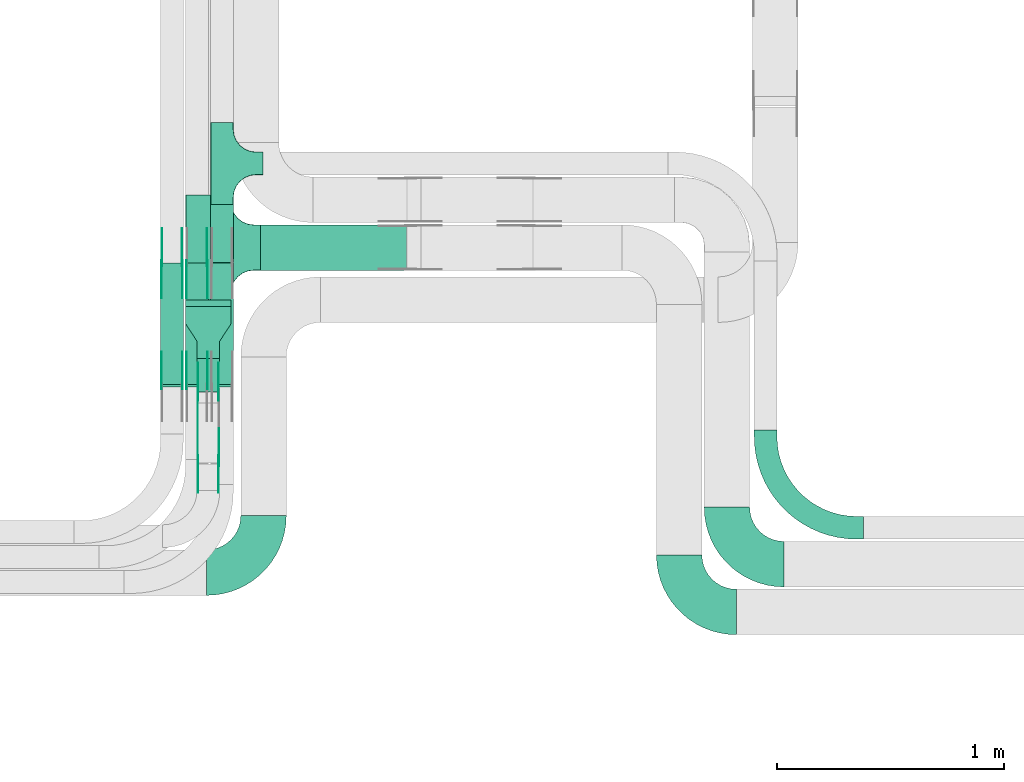
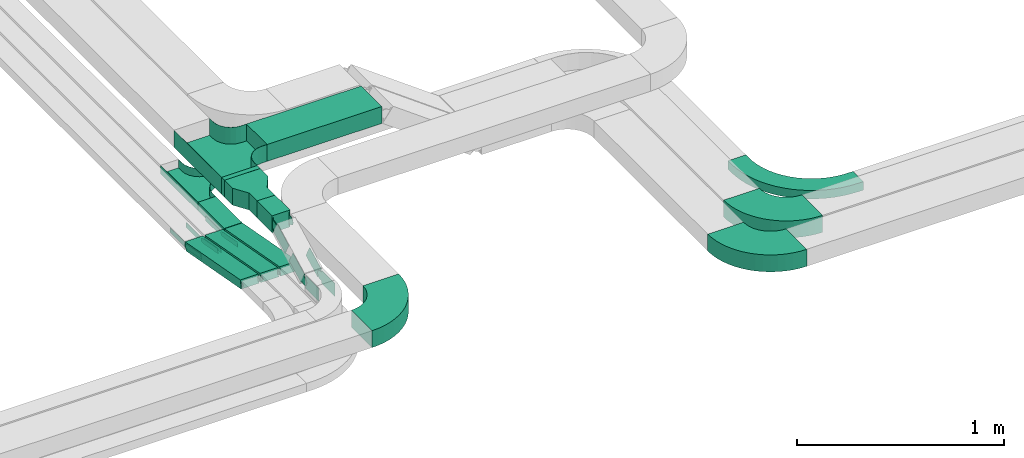
# One storey, part 10 of 23: 25 flow fittings, 7 flow segments.
"""IFC2X3 building model written with IfcOpenShell, lengths in millimetres."""

import ifcopenshell
import ifcopenshell.guid

model = None  # the IFC model being written
_history = None  # IfcOwnerHistory: only IFC2X3 demands one
_inside = {}  # id of a spatial element -> (the spatial element, [elements in it])
_under = {}  # id of a project, library or spatial element -> (it, [spatial elements below it])
_declared = {}  # id of a project -> (the project, [libraries it declares])
_typed = {}  # id of a type object -> (the type object, [elements of that type])
_made_of = {}  # id of a material, layer set ... -> (it, [elements and type objects made of it])


def new_model(schema):
    """Start an empty IFC model of exactly this schema.

    Asked for "IFC4X3", IfcOpenShell would pick the latest addendum, in which some entities
    have other attributes; the version numbers below select the first issue.
    IFC2X3 requires an IfcOwnerHistory on every rooted entity: one is made here for all.
    """
    global model, _history
    if schema == "IFC4X3":
        model = ifcopenshell.file(schema_version=(4, 3, 0, 0))
    else:
        model = ifcopenshell.file(schema=schema)
    _inside.clear()
    _under.clear()
    _declared.clear()
    _typed.clear()
    _made_of.clear()
    _history = None
    if model.schema == "IFC2X3":
        org = make("IfcOrganization", Name="unknown")
        user = make(
            "IfcPersonAndOrganization",
            ThePerson=make("IfcPerson", FamilyName="unknown"),
            TheOrganization=org,
        )
        app = make(
            "IfcApplication",
            ApplicationDeveloper=org,
            Version="unknown",
            ApplicationFullName="unknown",
            ApplicationIdentifier="unknown",
        )
        _history = make(
            "IfcOwnerHistory",
            OwningUser=user,
            OwningApplication=app,
            ChangeAction="ADDED",
            CreationDate=0,
        )
    return model


def make(cls, **values):
    """One entity of the class cls with the attributes given. An attribute that is None is left unset."""
    return model.create_entity(
        cls, **{name: value for name, value in values.items() if value is not None}
    )


def entity(cls, *values):
    """Any entity or typed value of the class cls, its attributes in the order of the schema. None: left unset."""
    e = model.create_entity(cls)
    for i, value in enumerate(values):
        if value is not None:
            e[i] = value
    return e


def rooted(cls, **values):
    """An entity with a GlobalId (a new one), such as an element, a storey or a relation."""
    return make(cls, GlobalId=ifcopenshell.guid.new(), OwnerHistory=_history, **values)


def si_unit(unit_type, name, prefix=None):
    """IfcSIUnit, for example si_unit("LENGTHUNIT", "METRE", prefix="MILLI")."""
    return make("IfcSIUnit", UnitType=unit_type, Prefix=prefix, Name=name)


def converted_unit(unit_type, name, factor, base, dimensions=None, offset=None):
    """IfcConversionBasedUnit, such as the inch: factor (a typed value) times the base unit."""
    return make(
        "IfcConversionBasedUnit"
        if offset is None
        else "IfcConversionBasedUnitWithOffset",
        ConversionOffset=offset,
        Dimensions=None
        if dimensions is None
        else entity("IfcDimensionalExponents", *dimensions),
        UnitType=unit_type,
        Name=name,
        ConversionFactor=make(
            "IfcMeasureWithUnit", ValueComponent=factor, UnitComponent=base
        ),
    )


def derived_unit(unit_type, elements):
    """IfcDerivedUnit: a product of units, each with its exponent."""
    return make(
        "IfcDerivedUnit",
        Elements=[
            make("IfcDerivedUnitElement", Unit=unit, Exponent=power)
            for unit, power in elements
        ],
        UnitType=unit_type,
    )


def assignment(units):
    """IfcUnitAssignment: the units of a project."""
    return None if units is None else make("IfcUnitAssignment", Units=units)


def point(xyz):
    """IfcCartesianPoint."""
    return None if xyz is None else make("IfcCartesianPoint", Coordinates=xyz)


def direction(xyz):
    """IfcDirection."""
    return None if xyz is None else make("IfcDirection", DirectionRatios=xyz)


def frame(location, z_axis=None, x_axis=None):
    """IfcAxis2Placement3D, a coordinate frame: its origin and axes. An axis left out is left unset."""
    return make(
        "IfcAxis2Placement3D",
        Location=point(location),
        Axis=direction(z_axis),
        RefDirection=direction(x_axis),
    )


def frame_2d(location, x_axis=None):
    """IfcAxis2Placement2D, a coordinate frame in the plane: its origin and x axis."""
    return make(
        "IfcAxis2Placement2D", Location=point(location), RefDirection=direction(x_axis)
    )


def origin():
    """The frame at (0, 0, 0) with its axes left unset."""
    return frame((0.0, 0.0, 0.0))


def origin_2d_with_axis():
    """The frame at (0, 0) in the plane with the x axis (1, 0) written out."""
    return frame_2d((0.0, 0.0), x_axis=(1.0, 0.0))


def place(relative_to, where):
    """IfcLocalPlacement: puts the frame where relative to a parent placement (None: the world)."""
    return make(
        "IfcLocalPlacement", PlacementRelTo=relative_to, RelativePlacement=where
    )


def context(
    kind, dimensions, precision=None, world=None, true_north=None, identifier=None
):
    """IfcGeometricRepresentationContext, for example the 3D "Model" context."""
    return make(
        "IfcGeometricRepresentationContext",
        ContextIdentifier=identifier,
        ContextType=kind,
        CoordinateSpaceDimension=dimensions,
        Precision=precision,
        WorldCoordinateSystem=world,
        TrueNorth=true_north,
    )


def subcontext(parent, identifier, kind, view, scale=None):
    """IfcGeometricRepresentationSubContext, for example "Body" below "Model"."""
    return make(
        "IfcGeometricRepresentationSubContext",
        ContextIdentifier=identifier,
        ContextType=kind,
        ParentContext=parent,
        TargetScale=scale,
        TargetView=view,
    )


def project(units=None, contexts=None):
    """IfcProject with its units and contexts."""
    return rooted(
        "IfcProject",
        Name="project",
        RepresentationContexts=contexts,
        UnitsInContext=assignment(units),
    )


def spatial(cls, under=None, at=None, **own):
    """A site, building, storey or space (cls), placed at a placement, below another one or the project."""
    s = rooted(cls, ObjectPlacement=at, **own)
    if under is not None:
        _under.setdefault(under.id(), (under, []))[1].append(s)
    return s


def polyline(points):
    """IfcPolyline through the points."""
    return make("IfcPolyline", Points=[point(p) for p in points])


def circle_curve(where, radius):
    """IfcCircle in the frame where."""
    return make("IfcCircle", Position=where, Radius=radius)


def parameter(value):
    """IfcParameterValue: where a trimmed curve begins or ends, as a parameter of its basis curve."""
    return model.create_entity("IfcParameterValue", value)


def trimmed(basis, trim1, trim2, sense, master):
    """IfcTrimmedCurve: the piece of a basis curve between two trims."""
    return make(
        "IfcTrimmedCurve",
        BasisCurve=basis,
        Trim1=trim1,
        Trim2=trim2,
        SenseAgreement=sense,
        MasterRepresentation=master,
    )


def segment(curve, same_sense, transition):
    """IfcCompositeCurveSegment."""
    return make(
        "IfcCompositeCurveSegment",
        Transition=transition,
        SameSense=same_sense,
        ParentCurve=curve,
    )


def composite_curve(segments, self_intersect=None):
    """IfcCompositeCurve: segments joined end to end."""
    return make("IfcCompositeCurve", Segments=segments, SelfIntersect=self_intersect)


def profile(cls, at=None, kind="AREA", **sizes):
    """A parametric profile (cls). Its sizes go by their IFC names, for example OverallWidth=200.0."""
    return make(cls, ProfileType=kind, Position=at, **sizes)


def rectangle(**sizes):
    """IfcRectangleProfileDef."""
    return profile("IfcRectangleProfileDef", **sizes)


def outline(outer, holes=None, kind="AREA"):
    """IfcArbitraryClosedProfileDef: a profile drawn as a closed curve; with holes, ...WithVoids."""
    if holes is None:
        return make("IfcArbitraryClosedProfileDef", ProfileType=kind, OuterCurve=outer)
    return make(
        "IfcArbitraryProfileDefWithVoids",
        ProfileType=kind,
        OuterCurve=outer,
        InnerCurves=holes,
    )


def extrude(swept, where, along, depth):
    """IfcExtrudedAreaSolid: the profile swept, set in the frame where, extruded along a direction by depth."""
    return make(
        "IfcExtrudedAreaSolid",
        SweptArea=swept,
        Position=where,
        ExtrudedDirection=direction(along),
        Depth=depth,
    )


def faces_of(points, faces, orient=None, outer=None):
    """IfcFace entities. A face is a list of loops; a loop is a list of indices into points, from 0.

    orient and outer hold one flag for each loop. By default every Orientation is true, the
    first loop of a face is its IfcFaceOuterBound and the others are IfcFaceBound.
    """
    made = []
    for i, loops in enumerate(faces):
        bounds = []
        for j, loop in enumerate(loops):
            is_outer = j == 0 if outer is None else outer[i][j]
            bounds.append(
                make(
                    "IfcFaceOuterBound" if is_outer else "IfcFaceBound",
                    Bound=make("IfcPolyLoop", Polygon=[points[k] for k in loop]),
                    Orientation=True if orient is None else orient[i][j],
                )
            )
        made.append(make("IfcFace", Bounds=bounds))
    return made


def faceted_brep(points, faces, orient=None, outer=None, voids=None):
    """IfcFacetedBrep: a solid bounded by flat faces; with voids (closed shells), ...WithVoids."""
    shared = [point(p) for p in points]
    hull = make("IfcClosedShell", CfsFaces=faces_of(shared, faces, orient, outer))
    if voids is None:
        return make("IfcFacetedBrep", Outer=hull)
    return make(
        "IfcFacetedBrepWithVoids",
        Outer=hull,
        Voids=[
            make(cls, CfsFaces=faces_of(shared, fs, o, b)) for cls, fs, o, b in voids
        ],
    )


def shape(context_of_items, identifier, shape_type, items):
    """IfcShapeRepresentation: the items that make up one representation, for example the "Body"."""
    return make(
        "IfcShapeRepresentation",
        ContextOfItems=context_of_items,
        RepresentationIdentifier=identifier,
        RepresentationType=shape_type,
        Items=items,
    )


def source(mapping_origin, context_of_items, identifier, shape_type, items):
    """IfcRepresentationMap: a shape defined once, which mapped items show again and again."""
    return make(
        "IfcRepresentationMap",
        MappingOrigin=mapping_origin,
        MappedRepresentation=shape(context_of_items, identifier, shape_type, items),
    )


def transform(
    local_origin,
    x_axis=None,
    y_axis=None,
    z_axis=None,
    scale=None,
    scale2=None,
    scale3=None,
    uniform=True,
):
    """IfcCartesianTransformationOperator3D, or its non-uniform kind. x_axis, y_axis, z_axis: its Axis1, 2, 3."""
    if uniform:
        return make(
            "IfcCartesianTransformationOperator3D",
            Axis1=direction(x_axis),
            Axis2=direction(y_axis),
            LocalOrigin=point(local_origin),
            Scale=scale,
            Axis3=direction(z_axis),
        )
    return make(
        "IfcCartesianTransformationOperator3DnonUniform",
        Axis1=direction(x_axis),
        Axis2=direction(y_axis),
        LocalOrigin=point(local_origin),
        Scale=scale,
        Axis3=direction(z_axis),
        Scale2=scale2,
        Scale3=scale3,
    )


def mapped(mapping_source, mapping_target):
    """IfcMappedItem: shows the shape of a source again, moved by a transform."""
    return make(
        "IfcMappedItem", MappingSource=mapping_source, MappingTarget=mapping_target
    )


def material(Name=None, Category=None):
    """IfcMaterial."""
    return make("IfcMaterial", Name=Name, Category=Category)


def made_of(thing, what):
    """Note that an element or type object is made of a material, layer set ...; save() writes the relation."""
    if what is not None:
        _made_of.setdefault(what.id(), (what, []))[1].append(thing)
    return thing


def type_object(cls, material=None, **own):
    """A type object (cls), such as IfcWallType, which elements share."""
    return made_of(rooted(cls, **own), material)


def type_shapes(of_type, sources):
    """Give a type object the sources (RepresentationMaps) that its elements show as mapped items."""
    of_type.RepresentationMaps = sources


def element(
    cls,
    number,
    at=None,
    inside=None,
    cuts=None,
    type_object=None,
    material=None,
    context=None,
    identifier="Body",
    shape_type=None,
    held_by="IfcProductDefinitionShape",
    body=None,
    shapes=None,
    **own,
):
    """One element of the class cls, such as IfcWall. Its Tag is "e" and its number.

    at: its placement. inside: the storey or other place that contains it. cuts: it is an
    opening in that element (IfcRelVoidsElement). A single representation is given by context,
    identifier, shape_type and body (its items); several are given by shapes. held_by: the class
    of the entity that holds the representations. save() writes the other relations.
    """
    e = rooted(cls, Tag="e%d" % number, ObjectPlacement=at, **own)
    if body is not None:
        shapes = [shape(context, identifier, shape_type, body)]
    if shapes is not None:
        e.Representation = make(held_by, Representations=shapes)
    if inside is not None:
        _inside.setdefault(inside.id(), (inside, []))[1].append(e)
    if cuts is not None:
        rooted(
            "IfcRelVoidsElement", RelatingBuildingElement=cuts, RelatedOpeningElement=e
        )
    if type_object is not None:
        _typed.setdefault(type_object.id(), (type_object, []))[1].append(e)
    return made_of(e, material)


def aggregate(whole, parts):
    """IfcRelAggregates: a whole, such as a stair, and the parts it consists of."""
    return rooted("IfcRelAggregates", RelatingObject=whole, RelatedObjects=parts)


def save(model, path):
    """Write the relations noted so far, then the file.

    IfcRelAggregates (storeys below a building ...), IfcRelContainedInSpatialStructure (elements
    in a storey), IfcRelDefinesByType, IfcRelAssociatesMaterial and IfcRelDeclares: one each for
    every whole, place, type object, material and project.
    """
    for whole, parts in _under.values():
        aggregate(whole, parts)
    for where, things in _inside.values():
        rooted(
            "IfcRelContainedInSpatialStructure",
            RelatedElements=things,
            RelatingStructure=where,
        )
    for kind, things in _typed.values():
        rooted("IfcRelDefinesByType", RelatedObjects=things, RelatingType=kind)
    for what, things in _made_of.values():
        rooted("IfcRelAssociatesMaterial", RelatedObjects=things, RelatingMaterial=what)
    for by, libraries in _declared.values():
        rooted("IfcRelDeclares", RelatingContext=by, RelatedDefinitions=libraries)
    model.write(path)


model = new_model("IFC2X3")

# Units and contexts
model_context = context("Model", 3, precision=0.01, world=origin(), true_north=direction((6.12303176911189e-17, 1.0)))
body_context = subcontext(model_context, "Body", "Model", "MODEL_VIEW")
ifc_project = project(units=[si_unit("LENGTHUNIT", "METRE", prefix="MILLI"), si_unit("AREAUNIT", "SQUARE_METRE"), si_unit("VOLUMEUNIT", "CUBIC_METRE"), converted_unit("PLANEANGLEUNIT", "DEGREE", entity("IfcRatioMeasure", 0.0174532925199433), si_unit("PLANEANGLEUNIT", "RADIAN"), dimensions=[0, 0, 0, 0, 0, 0, 0]), si_unit("MASSUNIT", "GRAM", prefix="KILO"), derived_unit("MASSDENSITYUNIT", [(si_unit("MASSUNIT", "GRAM", prefix="KILO"), 1), (si_unit("LENGTHUNIT", "METRE"), -3)]), derived_unit("MOMENTOFINERTIAUNIT", [(si_unit("LENGTHUNIT", "METRE"), 4)]), si_unit("TIMEUNIT", "SECOND"), si_unit("FREQUENCYUNIT", "HERTZ"), si_unit("THERMODYNAMICTEMPERATUREUNIT", "DEGREE_CELSIUS"), derived_unit("THERMALTRANSMITTANCEUNIT", [(si_unit("MASSUNIT", "GRAM", prefix="KILO"), 1), (si_unit("THERMODYNAMICTEMPERATUREUNIT", "KELVIN"), -1), (si_unit("TIMEUNIT", "SECOND"), -3)]), derived_unit("VOLUMETRICFLOWRATEUNIT", [(si_unit("LENGTHUNIT", "METRE"), 3), (si_unit("TIMEUNIT", "SECOND"), -1)]), derived_unit("MASSFLOWRATEUNIT", [(si_unit("MASSUNIT", "GRAM", prefix="KILO"), 1), (si_unit("TIMEUNIT", "SECOND"), -1)]), derived_unit("ROTATIONALFREQUENCYUNIT", [(si_unit("TIMEUNIT", "SECOND"), -1)]), si_unit("ELECTRICCURRENTUNIT", "AMPERE"), si_unit("ELECTRICVOLTAGEUNIT", "VOLT"), si_unit("POWERUNIT", "WATT"), si_unit("FORCEUNIT", "NEWTON", prefix="KILO"), si_unit("ILLUMINANCEUNIT", "LUX"), si_unit("LUMINOUSFLUXUNIT", "LUMEN"), si_unit("LUMINOUSINTENSITYUNIT", "CANDELA"), derived_unit("USERDEFINED", [(si_unit("MASSUNIT", "GRAM", prefix="KILO"), -1), (si_unit("LENGTHUNIT", "METRE"), -2), (si_unit("TIMEUNIT", "SECOND"), 3), (si_unit("LUMINOUSFLUXUNIT", "LUMEN"), 1)]), derived_unit("LINEARVELOCITYUNIT", [(si_unit("LENGTHUNIT", "METRE"), 1), (si_unit("TIMEUNIT", "SECOND"), -1)]), si_unit("PRESSUREUNIT", "PASCAL"), derived_unit("USERDEFINED", [(si_unit("LENGTHUNIT", "METRE"), -2), (si_unit("MASSUNIT", "GRAM", prefix="KILO"), 1), (si_unit("TIMEUNIT", "SECOND"), -2)]), derived_unit("LINEARFORCEUNIT", [(si_unit("MASSUNIT", "GRAM", prefix="KILO"), 1), (si_unit("LENGTHUNIT", "METRE"), 1), (si_unit("TIMEUNIT", "SECOND"), -2), (si_unit("LENGTHUNIT", "METRE"), -1)]), derived_unit("PLANARFORCEUNIT", [(si_unit("MASSUNIT", "GRAM", prefix="KILO"), 1), (si_unit("LENGTHUNIT", "METRE"), 1), (si_unit("TIMEUNIT", "SECOND"), -2), (si_unit("LENGTHUNIT", "METRE"), -2)])], contexts=[model_context])

# Site, building, storey
site_placement = place(None, origin())
site = spatial("IfcSite", under=ifc_project, at=site_placement, CompositionType="ELEMENT")
building_placement = place(site_placement, origin())
building = spatial("IfcBuilding", under=site, at=building_placement, CompositionType="ELEMENT")
storey_placement = place(building_placement, frame((0.0, 0.0, 24000.0)))
storey = spatial("IfcBuildingStorey", under=building, at=storey_placement, CompositionType="ELEMENT", Elevation=24000.0)

# Flow segments
cable_carrier_segment_type = type_object("IfcCableCarrierSegmentType", PredefinedType="CABLETRAYSEGMENT")
flow_segment_1_placement = place(storey_placement, frame((33053.08, 10611.48, 2650.04)))
element("IfcFlowSegment", 1, at=flow_segment_1_placement, inside=storey, type_object=cable_carrier_segment_type, context=body_context, shape_type="SweptSolid", body=[
    extrude(rectangle(XDim=255.423874591191, YDim=100.000000000003, at=origin_2d_with_axis()), frame((50.0, 127.71, 0.0), z_axis=(0.0, 0.0, 1.0), x_axis=(0.0, -1.0, 0.0)), (0.0, 0.0, 1.0), 49.9999999999973),
])
flow_segment_2_placement = place(storey_placement, frame((32833.08, 10064.89, 2651.08)))
element("IfcFlowSegment", 2, at=flow_segment_2_placement, inside=storey, type_object=cable_carrier_segment_type, context=body_context, shape_type="SweptSolid", body=[
    extrude(rectangle(XDim=49.999999999997, YDim=543.827941763907, at=frame_2d((0.0, 0.0), x_axis=(0.0, 1.0))), frame((0.0, 271.94, 73.92), z_axis=(1.0, 0.0, 0.0), x_axis=(0.0, 0.983401255749196, -0.18144412415646)), (0.0, 0.0, 1.0), 100.000000000003),
])
for number, where in (
    (3, (32943.08, 10064.89, 2651.08)),
    (4, (33053.08, 10064.89, 2651.08)),
):
    element("IfcFlowSegment", number, at=place(storey_placement, frame(where)), inside=storey, type_object=cable_carrier_segment_type, context=body_context, shape_type="SweptSolid", body=[
        extrude(rectangle(XDim=49.999999999997, YDim=543.8279417639, at=frame_2d((0.0, 0.0), x_axis=(0.0, 1.0))), frame((0.0, 271.94, 73.92), z_axis=(1.0, 0.0, 0.0), x_axis=(0.0, 0.983401255749195, -0.181444124156462)), (0.0, 0.0, 1.0), 100.000000000003),
    ])
flow_segment_3_placement = place(storey_placement, frame((32943.08, 10418.71, 3040.0)))
element("IfcFlowSegment", 5, at=flow_segment_3_placement, inside=storey, type_object=cable_carrier_segment_type, context=body_context, shape_type="SweptSolid", body=[
    extrude(rectangle(XDim=28.1879194516785, YDim=199.999999999998, at=origin_2d_with_axis()), frame((100.0, 14.09, 0.0), z_axis=(0.0, 0.0, 1.0), x_axis=(0.0, -1.0, 0.0)), (0.0, 0.0, 1.0), 100.000000000003),
])
flow_segment_4_placement = place(storey_placement, frame((33273.08, 10576.9, 3040.0)))
element("IfcFlowSegment", 6, at=flow_segment_4_placement, inside=storey, type_object=cable_carrier_segment_type, context=body_context, shape_type="SweptSolid", body=[
    extrude(rectangle(XDim=641.371886509749, YDim=200.000000000002, at=origin_2d_with_axis()), frame((320.69, 100.0, 0.0)), (0.0, 0.0, 1.0), 100.000000000008),
])
flow_segment_5_placement = place(storey_placement, frame((32993.08, 10042.9, 3040.0)))
element("IfcFlowSegment", 7, at=flow_segment_5_placement, inside=storey, type_object=cable_carrier_segment_type, context=body_context, shape_type="SweptSolid", body=[
    extrude(rectangle(XDim=145.816041854674, YDim=100.000000000003, at=origin_2d_with_axis()), frame((50.0, 72.91, 0.0), z_axis=(0.0, 0.0, 1.0), x_axis=(0.0, -1.0, 0.0)), (0.0, 0.0, 1.0), 100.000000000003),
])

# Flow fittings
ifc_material_1 = material()
cable_carrier_fitting_type_1 = type_object("IfcCableCarrierFittingType", PredefinedType="NOTDEFINED", material=ifc_material_1)
shared_shape_1 = source(origin(), body_context, "Body", "SweptSolid", [
    extrude(outline(polyline([(-115.0, -100.0), (-38.33, -100.0), (38.33, -50.0), (115.0, -50.0), (115.0, 50.0), (38.33, 50.0), (-38.33, 100.0), (-115.0, 100.0), (-115.0, -100.0)])), frame((115.0, 0.0, -50.0)), (0.0, 0.0, 1.0), 100.0),
])
type_shapes(cable_carrier_fitting_type_1, [shared_shape_1])
flow_fitting_1_placement = place(storey_placement, frame((33043.08, 10418.71, 3090.0), z_axis=(0.0, 0.0, 1.0), x_axis=(0.0, -1.0, 0.0)))
element("IfcFlowFitting", 8, at=flow_fitting_1_placement, inside=storey, type_object=cable_carrier_fitting_type_1, material=ifc_material_1, Name="470_DKC_S5_adapter", context=body_context, shape_type="MappedRepresentation", body=[
    mapped(shared_shape_1, transform((0.0, 0.0, 0.0), scale=1.0)),
])
cable_carrier_fitting_type_2 = type_object("IfcCableCarrierFittingType", PredefinedType="NOTDEFINED", material=ifc_material_1)
shared_shape_2 = source(origin(), body_context, "Body", "Brep", [
    faceted_brep([(-53.41, -124.12, 25.0), (-50.0, -150.0, 25.0), (-50.0, -180.0, 25.0), (-49.2, -180.0, 25.0), (-49.2, -150.0, 25.0), (-52.63, -123.91, 25.0), (-62.7, -99.6, 25.0), (-78.72, -78.72, 25.0), (-99.6, -62.7, 25.0), (-123.91, -52.63, 25.0), (-150.0, -49.2, 25.0), (-180.0, -49.2, 25.0), (-180.0, -50.0, 25.0), (-150.0, -50.0, 25.0), (-124.12, -53.41, 25.0), (-100.0, -63.4, 25.0), (-79.29, -79.29, 25.0), (-63.4, -100.0, 25.0), (180.0, -50.0, 25.0), (180.0, -49.2, 25.0), (150.0, -49.2, 25.0), (123.91, -52.63, 25.0), (99.6, -62.7, 25.0), (78.72, -78.72, 25.0), (62.7, -99.6, 25.0), (52.63, -123.91, 25.0), (49.2, -150.0, 25.0), (49.2, -180.0, 25.0), (50.0, -180.0, 25.0), (50.0, -150.0, 25.0), (53.41, -124.12, 25.0), (63.4, -100.0, 25.0), (79.29, -79.29, 25.0), (100.0, -63.4, 25.0), (124.12, -53.41, 25.0), (150.0, -50.0, 25.0), (180.0, 49.2, 25.0), (180.0, 50.0, 25.0), (-180.0, 50.0, 25.0), (-180.0, 49.2, 25.0), (-180.0, -50.0, -25.0), (-180.0, 50.0, -25.0), (180.0, 50.0, -25.0), (180.0, -50.0, -25.0), (150.0, -50.0, -25.0), (124.12, -53.41, -25.0), (100.0, -63.4, -25.0), (79.29, -79.29, -25.0), (63.4, -100.0, -25.0), (53.41, -124.12, -25.0), (50.0, -150.0, -25.0), (50.0, -180.0, -25.0), (-50.0, -180.0, -25.0), (-50.0, -150.0, -25.0), (-53.41, -124.12, -25.0), (-63.4, -100.0, -25.0), (-79.29, -79.29, -25.0), (-100.0, -63.4, -25.0), (-124.12, -53.41, -25.0), (-150.0, -50.0, -25.0), (-50.0, -150.0, -24.2), (49.2, -180.0, -24.2), (-49.2, -180.0, -24.2), (-49.2, -150.0, -24.2), (-150.0, -49.2, -24.2), (-180.0, -49.2, -24.2), (180.0, -49.2, -24.2), (150.0, -49.2, -24.2), (-180.0, 49.2, -24.2), (-150.0, -50.0, -24.2), (150.0, -50.0, -24.2), (180.0, 49.2, -24.2), (49.2, -150.0, -24.2), (50.0, -150.0, -24.2), (-123.91, -52.63, -24.2), (-99.6, -62.7, -24.2), (-78.72, -78.72, -24.2), (-62.7, -99.6, -24.2), (-52.63, -123.91, -24.2), (52.63, -123.91, -24.2), (62.7, -99.6, -24.2), (78.72, -78.72, -24.2), (99.6, -62.7, -24.2), (123.91, -52.63, -24.2)], [[[0, 1, 2, 3, 4, 5, 6, 7, 8, 9, 10, 11, 12, 13, 14, 15, 16, 17]], [[18, 19, 20, 21, 22, 23, 24, 25, 26, 27, 28, 29, 30, 31, 32, 33, 34, 35]], [[36, 37, 38, 39]], [[40, 41, 42, 43, 44, 45, 46, 47, 48, 49, 50, 51, 52, 53, 54, 55, 56, 57, 58, 59]], [[2, 1, 60, 53, 52]], [[3, 2, 52, 51, 28, 27, 61, 62]], [[4, 3, 62, 63]], [[11, 10, 64, 65]], [[20, 19, 66, 67]], [[39, 38, 41, 40, 12, 11, 65, 68]], [[13, 12, 40, 59, 69]], [[18, 35, 70, 44, 43]], [[19, 18, 43, 42, 37, 36, 71, 66]], [[27, 26, 72, 61]], [[29, 28, 51, 50, 73]], [[38, 37, 42, 41]], [[36, 39, 68, 71]], [[68, 65, 64, 74, 75, 76, 77, 78, 63, 62, 61, 72, 79, 80, 81, 82, 83, 67, 66, 71]], [[14, 13, 69, 59, 58]], [[58, 57, 15, 14]], [[15, 57, 56, 16]], [[0, 17, 55, 54]], [[0, 54, 53, 60, 1]], [[55, 17, 16, 56]], [[5, 4, 63, 78]], [[6, 5, 78, 77]], [[7, 6, 77, 76]], [[8, 7, 76, 75]], [[9, 8, 75, 74]], [[10, 9, 74, 64]], [[21, 20, 67, 83]], [[22, 21, 83, 82]], [[23, 22, 82, 81]], [[81, 80, 24, 23]], [[24, 80, 79, 25]], [[79, 72, 26, 25]], [[30, 29, 73, 50, 49]], [[31, 30, 49, 48]], [[31, 48, 47, 32]], [[33, 32, 47, 46]], [[45, 34, 33, 46]], [[34, 45, 44, 70, 35]]]),
])
type_shapes(cable_carrier_fitting_type_2, [shared_shape_2])
flow_fitting_2_placement = place(storey_placement, frame((33103.08, 11046.9, 2675.04), z_axis=(0.0, 0.0, 1.0), x_axis=(0.0, 1.0, 0.0)))
element("IfcFlowFitting", 9, at=flow_fitting_2_placement, inside=storey, type_object=cable_carrier_fitting_type_2, material=ifc_material_1, Name="470_DKC_S5_T", context=body_context, shape_type="MappedRepresentation", body=[
    mapped(shared_shape_2, transform((0.0, 0.0, 0.0), scale=1.0)),
])
cable_carrier_fitting_type_3 = type_object("IfcCableCarrierFittingType", PredefinedType="NOTDEFINED", material=ifc_material_1)
shared_shape_3 = source(origin(), body_context, "Body", "Brep", [
    faceted_brep([(-103.41, -174.12, 50.0), (-100.0, -200.0, 50.0), (-100.0, -230.0, 50.0), (-99.2, -230.0, 50.0), (-99.2, -200.0, 50.0), (-102.63, -173.91, 50.0), (-112.7, -149.6, 50.0), (-128.72, -128.72, 50.0), (-149.6, -112.7, 50.0), (-173.91, -102.63, 50.0), (-200.0, -99.2, 50.0), (-230.0, -99.2, 50.0), (-230.0, -100.0, 50.0), (-200.0, -100.0, 50.0), (-174.12, -103.41, 50.0), (-150.0, -113.4, 50.0), (-129.29, -129.29, 50.0), (-113.4, -150.0, 50.0), (230.0, -100.0, 50.0), (230.0, -99.2, 50.0), (200.0, -99.2, 50.0), (173.91, -102.63, 50.0), (149.6, -112.7, 50.0), (128.72, -128.72, 50.0), (112.7, -149.6, 50.0), (102.63, -173.91, 50.0), (99.2, -200.0, 50.0), (99.2, -230.0, 50.0), (100.0, -230.0, 50.0), (100.0, -200.0, 50.0), (103.41, -174.12, 50.0), (113.4, -150.0, 50.0), (129.29, -129.29, 50.0), (150.0, -113.4, 50.0), (174.12, -103.41, 50.0), (200.0, -100.0, 50.0), (230.0, 99.2, 50.0), (230.0, 100.0, 50.0), (-230.0, 100.0, 50.0), (-230.0, 99.2, 50.0), (-230.0, -100.0, -50.0), (-230.0, 100.0, -50.0), (230.0, 100.0, -50.0), (230.0, -100.0, -50.0), (200.0, -100.0, -50.0), (174.12, -103.41, -50.0), (150.0, -113.4, -50.0), (129.29, -129.29, -50.0), (113.4, -150.0, -50.0), (103.41, -174.12, -50.0), (100.0, -200.0, -50.0), (100.0, -230.0, -50.0), (-100.0, -230.0, -50.0), (-100.0, -200.0, -50.0), (-103.41, -174.12, -50.0), (-113.4, -150.0, -50.0), (-129.29, -129.29, -50.0), (-150.0, -113.4, -50.0), (-174.12, -103.41, -50.0), (-200.0, -100.0, -50.0), (-100.0, -200.0, -49.2), (99.2, -230.0, -49.2), (-99.2, -230.0, -49.2), (-99.2, -200.0, -49.2), (-200.0, -99.2, -49.2), (-230.0, -99.2, -49.2), (230.0, -99.2, -49.2), (200.0, -99.2, -49.2), (-230.0, 99.2, -49.2), (-200.0, -100.0, -49.2), (200.0, -100.0, -49.2), (230.0, 99.2, -49.2), (99.2, -200.0, -49.2), (100.0, -200.0, -49.2), (-173.91, -102.63, -49.2), (-149.6, -112.7, -49.2), (-128.72, -128.72, -49.2), (-112.7, -149.6, -49.2), (-102.63, -173.91, -49.2), (102.63, -173.91, -49.2), (112.7, -149.6, -49.2), (128.72, -128.72, -49.2), (149.6, -112.7, -49.2), (173.91, -102.63, -49.2)], [[[0, 1, 2, 3, 4, 5, 6, 7, 8, 9, 10, 11, 12, 13, 14, 15, 16, 17]], [[18, 19, 20, 21, 22, 23, 24, 25, 26, 27, 28, 29, 30, 31, 32, 33, 34, 35]], [[36, 37, 38, 39]], [[40, 41, 42, 43, 44, 45, 46, 47, 48, 49, 50, 51, 52, 53, 54, 55, 56, 57, 58, 59]], [[2, 1, 60, 53, 52]], [[3, 2, 52, 51, 28, 27, 61, 62]], [[4, 3, 62, 63]], [[11, 10, 64, 65]], [[20, 19, 66, 67]], [[39, 38, 41, 40, 12, 11, 65, 68]], [[13, 12, 40, 59, 69]], [[18, 35, 70, 44, 43]], [[19, 18, 43, 42, 37, 36, 71, 66]], [[27, 26, 72, 61]], [[29, 28, 51, 50, 73]], [[38, 37, 42, 41]], [[36, 39, 68, 71]], [[68, 65, 64, 74, 75, 76, 77, 78, 63, 62, 61, 72, 79, 80, 81, 82, 83, 67, 66, 71]], [[14, 13, 69, 59, 58]], [[15, 14, 58, 57]], [[57, 56, 16, 15]], [[17, 16, 56, 55]], [[0, 17, 55, 54]], [[1, 0, 54, 53, 60]], [[5, 78, 77, 6]], [[6, 77, 76, 7]], [[63, 78, 5, 4]], [[8, 75, 74, 9]], [[9, 74, 64, 10]], [[7, 76, 75, 8]], [[21, 83, 82, 22]], [[22, 82, 81, 23]], [[67, 83, 21, 20]], [[24, 80, 79, 25]], [[25, 79, 72, 26]], [[23, 81, 80, 24]], [[30, 29, 73, 50, 49]], [[31, 30, 49, 48]], [[32, 31, 48, 47]], [[34, 33, 46, 45]], [[34, 45, 44, 70, 35]], [[46, 33, 32, 47]]]),
])
type_shapes(cable_carrier_fitting_type_3, [shared_shape_3])
flow_fitting_3_placement = place(storey_placement, frame((33043.08, 10676.9, 3090.0), z_axis=(0.0, 0.0, 1.0), x_axis=(0.0, 1.0, 0.0)))
element("IfcFlowFitting", 10, at=flow_fitting_3_placement, inside=storey, type_object=cable_carrier_fitting_type_3, material=ifc_material_1, Name="470_DKC_S5_T", context=body_context, shape_type="MappedRepresentation", body=[
    mapped(shared_shape_3, transform((0.0, 0.0, 0.0), scale=1.0)),
])
cable_carrier_fitting_type_4 = type_object("IfcCableCarrierFittingType", Name="470_DKC_S5_Variable Angle Elbow 0-45:-", PredefinedType="NOTDEFINED", material=ifc_material_1)
shared_shape_4 = source(origin(), body_context, "Body", "SweptSolid", [
    extrude(outline(composite_curve([segment(polyline([(-125.75, -225.25), (-124.75, -225.25)]), True, "CONTINUOUS"), segment(trimmed(circle_curve(frame_2d((-124.75, 124.75), x_axis=(0.0, -1.0)), 350.0), [parameter(0.0)], [parameter(90.0000000000001)], True, "PARAMETER"), True, "CONTINUOUS"), segment(polyline([(225.25, 124.75), (225.25, 125.75)]), True, "CONTINUOUS"), segment(polyline([(225.25, 125.75), (25.25, 125.75)]), True, "CONTINUOUS"), segment(polyline([(25.25, 125.75), (25.25, 124.75)]), True, "CONTINUOUS"), segment(trimmed(circle_curve(frame_2d((-124.75, 124.75), x_axis=(0.0, -1.0)), 150.0), [parameter(0.0)], [parameter(90.0000000000001)], True, "PARAMETER"), False, "CONTINUOUS"), segment(polyline([(-124.75, -25.25), (-125.75, -25.25)]), True, "CONTINUOUS"), segment(polyline([(-125.75, -25.25), (-125.75, -225.25)]), True, "CONTINUOUS")], self_intersect=False)), frame((-125.25, 125.25, -50.0)), (0.0, 0.0, 1.0), 100.0),
])
type_shapes(cable_carrier_fitting_type_4, [shared_shape_4])
flow_fitting_4_placement = place(storey_placement, frame((33285.89, 9247.82, 2940.0)))
element("IfcFlowFitting", 11, at=flow_fitting_4_placement, inside=storey, type_object=cable_carrier_fitting_type_4, material=ifc_material_1, Name="470_DKC_S5_Variable Angle Elbow 0-45:-", ObjectType="470_DKC_S5_Variable Angle Elbow 0-45:-", context=body_context, shape_type="MappedRepresentation", body=[
    mapped(shared_shape_4, transform((0.0, 0.0, 0.0), scale=1.0)),
])
for number, where, z_axis, x_axis, name in (
    (12, (35113.08, 9074.94, 2710.0), (0.0, 0.0, 1.0), (0.0, -1.0, 0.0), "470_DKC_S5_Variable Angle Elbow 0-45:-"),
    (13, (35323.08, 9284.94, 2710.0), (0.0, 0.0, 1.0), (0.0, -1.0, 0.0), "470_DKC_S5_Variable Angle Elbow 0-45:-"),
):
    element("IfcFlowFitting", number, at=place(storey_placement, frame(where, z_axis=z_axis, x_axis=x_axis)), inside=storey, type_object=cable_carrier_fitting_type_4, material=ifc_material_1, Name=name, ObjectType="470_DKC_S5_Variable Angle Elbow 0-45:-", context=body_context, shape_type="MappedRepresentation", body=[
        mapped(shared_shape_4, transform((0.0, 0.0, 0.0), scale=1.0)),
    ])
ifc_material_2 = material(Name="G")
cable_carrier_fitting_type_5 = type_object("IfcCableCarrierFittingType", PredefinedType="NOTDEFINED", material=ifc_material_2)
shared_shape_5 = source(origin(), body_context, "Body", "SweptSolid", [
    extrude(outline(composite_curve([segment(trimmed(circle_curve(frame_2d((-44.59, 0.0), x_axis=(1.0, 0.0)), 12.5), [parameter(90.0000000000007)], [parameter(270.0)], True, "PARAMETER"), True, "CONTINUOUS"), segment(polyline([(-44.59, -12.5), (-33.09, -12.5)]), True, "CONTINUOUS"), segment(polyline([(-33.09, -12.5), (-31.23, -14.5)]), True, "CONTINUOUS"), segment(polyline([(-31.23, -14.5), (108.91, -14.5)]), True, "CONTINUOUS"), segment(polyline([(108.91, -14.5), (108.91, 14.5)]), True, "CONTINUOUS"), segment(polyline([(108.91, 14.5), (-31.23, 14.5)]), True, "CONTINUOUS"), segment(polyline([(-31.23, 14.5), (-33.09, 12.5)]), True, "CONTINUOUS"), segment(polyline([(-33.09, 12.5), (-44.59, 12.5)]), True, "CONTINUOUS")], self_intersect=False)), frame((44.59, 0.0, 0.0), z_axis=(0.0, 0.0, -1.0), x_axis=(1.0, 0.0, 0.0)), (0.0, 0.0, -1.0), 2.0),
])
type_shapes(cable_carrier_fitting_type_5, [shared_shape_5])
for number, where, z_axis, x_axis in (
    (14, (32837.62, 10065.84, 2775.0), (-1.0, 0.0, 0.0), (0.0, 0.983401255749196, -0.181444124156458)),
    (15, (32837.62, 10607.82, 2675.0), (-1.0, 0.0, 0.0), (0.0, -0.983401255749196, 0.181444124156458)),
):
    element("IfcFlowFitting", number, at=place(storey_placement, frame(where, z_axis=z_axis, x_axis=x_axis)), inside=storey, type_object=cable_carrier_fitting_type_5, material=ifc_material_2, context=body_context, shape_type="MappedRepresentation", body=[
        mapped(shared_shape_5, transform((0.0, 0.0, 0.0), scale=1.0)),
    ])
cable_carrier_fitting_type_6 = type_object("IfcCableCarrierFittingType", PredefinedType="NOTDEFINED", material=ifc_material_2)
type_shapes(cable_carrier_fitting_type_6, [shared_shape_5])
flow_fitting_5_placement = place(storey_placement, frame((32926.54, 10607.82, 2675.0), z_axis=(1.0, 0.0, 0.0), x_axis=(0.0, 1.0, 0.0)))
element("IfcFlowFitting", 16, at=flow_fitting_5_placement, inside=storey, type_object=cable_carrier_fitting_type_6, material=ifc_material_2, context=body_context, shape_type="MappedRepresentation", body=[
    mapped(shared_shape_5, transform((0.0, 0.0, 0.0), scale=1.0)),
])
for number, where, z_axis, x_axis in (
    (17, (32947.62, 10065.84, 2775.0), (-1.0, 0.0, 0.0), (0.0, 0.983401255749196, -0.181444124156458)),
    (18, (32947.62, 10607.82, 2675.0), (-1.0, 0.0, 0.0), (0.0, -0.983401255749196, 0.181444124156458)),
):
    element("IfcFlowFitting", number, at=place(storey_placement, frame(where, z_axis=z_axis, x_axis=x_axis)), inside=storey, type_object=cable_carrier_fitting_type_5, material=ifc_material_2, context=body_context, shape_type="MappedRepresentation", body=[
        mapped(shared_shape_5, transform((0.0, 0.0, 0.0), scale=1.0)),
    ])
flow_fitting_6_placement = place(storey_placement, frame((33036.54, 10607.82, 2675.0), z_axis=(1.0, 0.0, 0.0), x_axis=(0.0, 1.0, 0.0)))
element("IfcFlowFitting", 19, at=flow_fitting_6_placement, inside=storey, type_object=cable_carrier_fitting_type_6, material=ifc_material_2, context=body_context, shape_type="MappedRepresentation", body=[
    mapped(shared_shape_5, transform((0.0, 0.0, 0.0), scale=1.0)),
])
cable_carrier_fitting_type_7 = type_object("IfcCableCarrierFittingType", PredefinedType="NOTDEFINED", material=ifc_material_2)
shared_shape_6 = source(origin(), body_context, "Body", "SweptSolid", [
    extrude(outline(composite_curve([segment(trimmed(circle_curve(frame_2d((-44.59, 0.0), x_axis=(1.0, 0.0)), 12.5), [parameter(90.0000000000007)], [parameter(270.0)], True, "PARAMETER"), True, "CONTINUOUS"), segment(polyline([(-44.59, -12.5), (-33.09, -12.5)]), True, "CONTINUOUS"), segment(polyline([(-33.09, -12.5), (-31.23, -14.5)]), True, "CONTINUOUS"), segment(polyline([(-31.23, -14.5), (108.91, -14.5)]), True, "CONTINUOUS"), segment(polyline([(108.91, -14.5), (108.91, 14.5)]), True, "CONTINUOUS"), segment(polyline([(108.91, 14.5), (-31.23, 14.5)]), True, "CONTINUOUS"), segment(polyline([(-31.23, 14.5), (-33.09, 12.5)]), True, "CONTINUOUS"), segment(polyline([(-33.09, 12.5), (-44.59, 12.5)]), True, "CONTINUOUS")], self_intersect=False)), frame((44.59, 0.0, 0.0)), (0.0, 0.0, 1.0), 2.0),
])
type_shapes(cable_carrier_fitting_type_7, [shared_shape_6])
for number, where, z_axis, x_axis in (
    (20, (32928.54, 10065.84, 2775.0), (1.0, 0.0, 0.0), (0.0, 0.983401255749196, -0.181444124156458)),
    (21, (32928.54, 10607.82, 2675.0), (1.0, 0.0, 0.0), (0.0, -0.983401255749196, 0.181444124156458)),
):
    element("IfcFlowFitting", number, at=place(storey_placement, frame(where, z_axis=z_axis, x_axis=x_axis)), inside=storey, type_object=cable_carrier_fitting_type_7, material=ifc_material_2, context=body_context, shape_type="MappedRepresentation", body=[
        mapped(shared_shape_6, transform((0.0, 0.0, 0.0), scale=1.0)),
    ])
cable_carrier_fitting_type_8 = type_object("IfcCableCarrierFittingType", PredefinedType="NOTDEFINED", material=ifc_material_2)
type_shapes(cable_carrier_fitting_type_8, [shared_shape_6])
flow_fitting_7_placement = place(storey_placement, frame((32839.62, 10607.82, 2675.0), z_axis=(-1.0, 0.0, 0.0), x_axis=(0.0, 1.0, 0.0)))
element("IfcFlowFitting", 22, at=flow_fitting_7_placement, inside=storey, type_object=cable_carrier_fitting_type_8, material=ifc_material_2, context=body_context, shape_type="MappedRepresentation", body=[
    mapped(shared_shape_6, transform((0.0, 0.0, 0.0), scale=1.0)),
])
for number, where, z_axis, x_axis in (
    (23, (33038.54, 10065.84, 2775.0), (1.0, 0.0, 0.0), (0.0, 0.983401255749196, -0.181444124156458)),
    (24, (33038.54, 10607.82, 2675.0), (1.0, 0.0, 0.0), (0.0, -0.983401255749196, 0.181444124156458)),
):
    element("IfcFlowFitting", number, at=place(storey_placement, frame(where, z_axis=z_axis, x_axis=x_axis)), inside=storey, type_object=cable_carrier_fitting_type_7, material=ifc_material_2, context=body_context, shape_type="MappedRepresentation", body=[
        mapped(shared_shape_6, transform((0.0, 0.0, 0.0), scale=1.0)),
    ])
cable_carrier_fitting_type_9 = type_object("IfcCableCarrierFittingType", PredefinedType="NOTDEFINED", material=ifc_material_2)
shared_shape_7 = source(origin(), body_context, "Body", "SweptSolid", [
    extrude(outline(composite_curve([segment(trimmed(circle_curve(frame_2d((-41.47, 0.0), x_axis=(1.0, 0.0)), 25.0), [parameter(90.0000000000007)], [parameter(270.0)], True, "PARAMETER"), True, "CONTINUOUS"), segment(polyline([(-41.47, -25.0), (-29.97, -25.0)]), True, "CONTINUOUS"), segment(polyline([(-29.97, -25.0), (-28.1, -38.5)]), True, "CONTINUOUS"), segment(polyline([(-28.1, -38.5), (99.53, -38.5)]), True, "CONTINUOUS"), segment(polyline([(99.53, -38.5), (99.53, 38.5)]), True, "CONTINUOUS"), segment(polyline([(99.53, 38.5), (-28.1, 38.5)]), True, "CONTINUOUS"), segment(polyline([(-28.1, 38.5), (-29.97, 25.0)]), True, "CONTINUOUS"), segment(polyline([(-29.97, 25.0), (-41.47, 25.0)]), True, "CONTINUOUS")], self_intersect=False)), frame((41.47, 0.0, 0.0), z_axis=(0.0, 0.0, -1.0), x_axis=(1.0, 0.0, 0.0)), (0.0, 0.0, -1.0), 2.0),
])
type_shapes(cable_carrier_fitting_type_9, [shared_shape_7])
flow_fitting_8_placement = place(storey_placement, frame((32999.62, 10028.71, 3090.0), z_axis=(-1.0, 0.0, 0.0), x_axis=(0.0, 1.0, 0.0)))
element("IfcFlowFitting", 25, at=flow_fitting_8_placement, inside=storey, type_object=cable_carrier_fitting_type_9, material=ifc_material_2, context=body_context, shape_type="MappedRepresentation", body=[
    mapped(shared_shape_7, transform((0.0, 0.0, 0.0), scale=1.0)),
])
cable_carrier_fitting_type_10 = type_object("IfcCableCarrierFittingType", PredefinedType="NOTDEFINED", material=ifc_material_2)
type_shapes(cable_carrier_fitting_type_10, [shared_shape_7])
flow_fitting_9_placement = place(storey_placement, frame((33088.54, 9739.83, 2940.0), z_axis=(1.0, 0.0, 0.0), x_axis=(0.0, 0.887490575455891, 0.460825865677017)))
element("IfcFlowFitting", 26, at=flow_fitting_9_placement, inside=storey, type_object=cable_carrier_fitting_type_10, material=ifc_material_2, context=body_context, shape_type="MappedRepresentation", body=[
    mapped(shared_shape_7, transform((0.0, 0.0, 0.0), scale=1.0)),
])
flow_fitting_10_placement = place(storey_placement, frame((32999.62, 9739.83, 2940.0), z_axis=(-1.0, 0.0, 0.0), x_axis=(0.0, -1.0, 0.0)))
element("IfcFlowFitting", 27, at=flow_fitting_10_placement, inside=storey, type_object=cable_carrier_fitting_type_9, material=ifc_material_2, context=body_context, shape_type="MappedRepresentation", body=[
    mapped(shared_shape_7, transform((0.0, 0.0, 0.0), scale=1.0)),
])
cable_carrier_fitting_type_11 = type_object("IfcCableCarrierFittingType", PredefinedType="NOTDEFINED", material=ifc_material_2)
shared_shape_8 = source(origin(), body_context, "Body", "SweptSolid", [
    extrude(outline(composite_curve([segment(trimmed(circle_curve(frame_2d((-41.47, 0.0), x_axis=(1.0, 0.0)), 25.0), [parameter(90.0000000000007)], [parameter(270.0)], True, "PARAMETER"), True, "CONTINUOUS"), segment(polyline([(-41.47, -25.0), (-29.97, -25.0)]), True, "CONTINUOUS"), segment(polyline([(-29.97, -25.0), (-28.1, -38.5)]), True, "CONTINUOUS"), segment(polyline([(-28.1, -38.5), (99.53, -38.5)]), True, "CONTINUOUS"), segment(polyline([(99.53, -38.5), (99.53, 38.5)]), True, "CONTINUOUS"), segment(polyline([(99.53, 38.5), (-28.1, 38.5)]), True, "CONTINUOUS"), segment(polyline([(-28.1, 38.5), (-29.97, 25.0)]), True, "CONTINUOUS"), segment(polyline([(-29.97, 25.0), (-41.47, 25.0)]), True, "CONTINUOUS")], self_intersect=False)), frame((41.47, 0.0, 0.0)), (0.0, 0.0, 1.0), 2.0),
])
type_shapes(cable_carrier_fitting_type_11, [shared_shape_8])
flow_fitting_11_placement = place(storey_placement, frame((32997.62, 10028.71, 3090.0), z_axis=(-1.0, 0.0, 0.0), x_axis=(0.0, -0.887490575455891, -0.460825865677017)))
element("IfcFlowFitting", 28, at=flow_fitting_11_placement, inside=storey, type_object=cable_carrier_fitting_type_11, material=ifc_material_2, context=body_context, shape_type="MappedRepresentation", body=[
    mapped(shared_shape_8, transform((0.0, 0.0, 0.0), scale=1.0)),
])
cable_carrier_fitting_type_12 = type_object("IfcCableCarrierFittingType", PredefinedType="NOTDEFINED", material=ifc_material_2)
type_shapes(cable_carrier_fitting_type_12, [shared_shape_8])
flow_fitting_12_placement = place(storey_placement, frame((33086.54, 10028.71, 3090.0), z_axis=(1.0, 0.0, 0.0), x_axis=(0.0, 1.0, 0.0)))
element("IfcFlowFitting", 29, at=flow_fitting_12_placement, inside=storey, type_object=cable_carrier_fitting_type_12, material=ifc_material_2, context=body_context, shape_type="MappedRepresentation", body=[
    mapped(shared_shape_8, transform((0.0, 0.0, 0.0), scale=1.0)),
])
flow_fitting_13_placement = place(storey_placement, frame((32997.62, 9739.83, 2940.0), z_axis=(-1.0, 0.0, 0.0), x_axis=(0.0, 0.887490575455891, 0.460825865677017)))
element("IfcFlowFitting", 30, at=flow_fitting_13_placement, inside=storey, type_object=cable_carrier_fitting_type_11, material=ifc_material_2, context=body_context, shape_type="MappedRepresentation", body=[
    mapped(shared_shape_8, transform((0.0, 0.0, 0.0), scale=1.0)),
])
flow_fitting_14_placement = place(storey_placement, frame((33086.54, 9739.83, 2940.0), z_axis=(1.0, 0.0, 0.0), x_axis=(0.0, -1.0, 0.0)))
element("IfcFlowFitting", 31, at=flow_fitting_14_placement, inside=storey, type_object=cable_carrier_fitting_type_12, material=ifc_material_2, context=body_context, shape_type="MappedRepresentation", body=[
    mapped(shared_shape_8, transform((0.0, 0.0, 0.0), scale=1.0)),
])
cable_carrier_fitting_type_13 = type_object("IfcCableCarrierFittingType", Name="470_DKC_S5_CPO 45 horizontal angle:-", PredefinedType="NOTDEFINED", material=ifc_material_1)
shared_shape_9 = source(origin(), body_context, "Body", "SweptSolid", [
    extrude(outline(composite_curve([segment(polyline([(-222.5, -257.5), (-192.5, -257.5)]), True, "CONTINUOUS"), segment(trimmed(circle_curve(frame_2d((-192.5, 192.5), x_axis=(0.0, -1.0)), 450.0), [parameter(0.0)], [parameter(90.0)], True, "PARAMETER"), True, "CONTINUOUS"), segment(polyline([(257.5, 192.5), (257.5, 222.5)]), True, "CONTINUOUS"), segment(polyline([(257.5, 222.5), (157.5, 222.5)]), True, "CONTINUOUS"), segment(polyline([(157.5, 222.5), (157.5, 192.5)]), True, "CONTINUOUS"), segment(trimmed(circle_curve(frame_2d((-192.5, 192.5), x_axis=(0.0, -1.0)), 350.0), [parameter(0.0)], [parameter(90.0)], True, "PARAMETER"), False, "CONTINUOUS"), segment(polyline([(-192.5, -157.5), (-222.5, -157.5)]), True, "CONTINUOUS"), segment(polyline([(-222.5, -157.5), (-222.5, -257.5)]), True, "CONTINUOUS")], self_intersect=False)), frame((-207.5, 207.5, -25.0)), (0.0, 0.0, 1.0), 50.0000000000002),
])
type_shapes(cable_carrier_fitting_type_13, [shared_shape_9])
flow_fitting_15_placement = place(storey_placement, frame((35493.08, 9444.94, 2685.0), z_axis=(0.0, 0.0, 1.0), x_axis=(0.0, -1.0, 0.0)))
element("IfcFlowFitting", 32, at=flow_fitting_15_placement, inside=storey, type_object=cable_carrier_fitting_type_13, material=ifc_material_1, Name="470_DKC_S5_45 horizontal angle", ObjectType="470_DKC_S5_CPO 45 horizontal angle:-", context=body_context, shape_type="MappedRepresentation", body=[
    mapped(shared_shape_9, transform((0.0, 0.0, 0.0), scale=1.0)),
])

save(model, "model.ifc")
